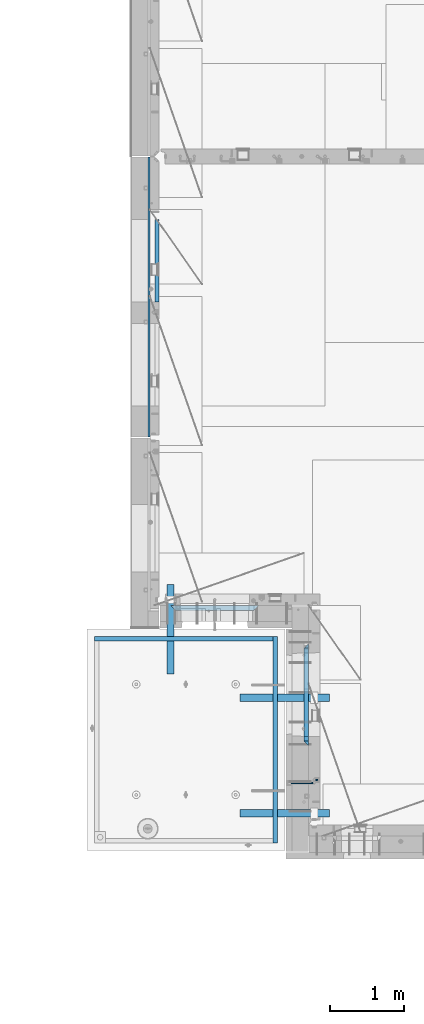
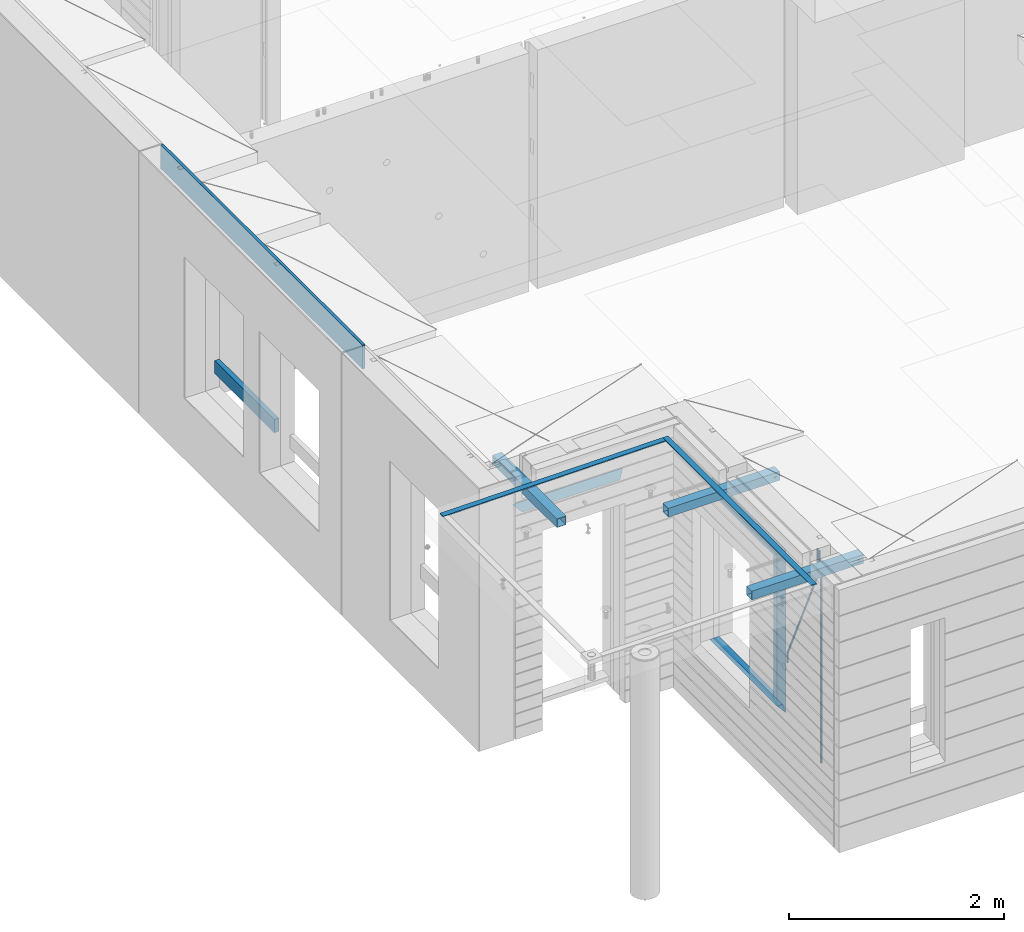
# One storey, part 88 of 341: 16 beams, 7 elements without a shape of their own.
"""IFC2X3 building model written with IfcOpenShell, lengths in millimetres."""

import ifcopenshell
import ifcopenshell.guid

model = None  # the IFC model being written
_history = None  # IfcOwnerHistory: only IFC2X3 demands one
_inside = {}  # id of a spatial element -> (the spatial element, [elements in it])
_under = {}  # id of a project, library or spatial element -> (it, [spatial elements below it])
_declared = {}  # id of a project -> (the project, [libraries it declares])
_typed = {}  # id of a type object -> (the type object, [elements of that type])
_made_of = {}  # id of a material, layer set ... -> (it, [elements and type objects made of it])


def new_model(schema):
    """Start an empty IFC model of exactly this schema.

    Asked for "IFC4X3", IfcOpenShell would pick the latest addendum, in which some entities
    have other attributes; the version numbers below select the first issue.
    IFC2X3 requires an IfcOwnerHistory on every rooted entity: one is made here for all.
    """
    global model, _history
    if schema == "IFC4X3":
        model = ifcopenshell.file(schema_version=(4, 3, 0, 0))
    else:
        model = ifcopenshell.file(schema=schema)
    _inside.clear()
    _under.clear()
    _declared.clear()
    _typed.clear()
    _made_of.clear()
    _history = None
    if model.schema == "IFC2X3":
        org = make("IfcOrganization", Name="unknown")
        user = make(
            "IfcPersonAndOrganization",
            ThePerson=make("IfcPerson", FamilyName="unknown"),
            TheOrganization=org,
        )
        app = make(
            "IfcApplication",
            ApplicationDeveloper=org,
            Version="unknown",
            ApplicationFullName="unknown",
            ApplicationIdentifier="unknown",
        )
        _history = make(
            "IfcOwnerHistory",
            OwningUser=user,
            OwningApplication=app,
            ChangeAction="ADDED",
            CreationDate=0,
        )
    return model


def make(cls, **values):
    """One entity of the class cls with the attributes given. An attribute that is None is left unset."""
    return model.create_entity(
        cls, **{name: value for name, value in values.items() if value is not None}
    )


def rooted(cls, **values):
    """An entity with a GlobalId (a new one), such as an element, a storey or a relation."""
    return make(cls, GlobalId=ifcopenshell.guid.new(), OwnerHistory=_history, **values)


def si_unit(unit_type, name, prefix=None):
    """IfcSIUnit, for example si_unit("LENGTHUNIT", "METRE", prefix="MILLI")."""
    return make("IfcSIUnit", UnitType=unit_type, Prefix=prefix, Name=name)


def assignment(units):
    """IfcUnitAssignment: the units of a project."""
    return None if units is None else make("IfcUnitAssignment", Units=units)


def point(xyz):
    """IfcCartesianPoint."""
    return None if xyz is None else make("IfcCartesianPoint", Coordinates=xyz)


def direction(xyz):
    """IfcDirection."""
    return None if xyz is None else make("IfcDirection", DirectionRatios=xyz)


def frame(location, z_axis=None, x_axis=None):
    """IfcAxis2Placement3D, a coordinate frame: its origin and axes. An axis left out is left unset."""
    return make(
        "IfcAxis2Placement3D",
        Location=point(location),
        Axis=direction(z_axis),
        RefDirection=direction(x_axis),
    )


def origin_with_axes():
    """The frame at (0, 0, 0) with the z axis (0, 0, 1) and the x axis (1, 0, 0) written out."""
    return frame((0.0, 0.0, 0.0), z_axis=(0.0, 0.0, 1.0), x_axis=(1.0, 0.0, 0.0))


def place(relative_to, where):
    """IfcLocalPlacement: puts the frame where relative to a parent placement (None: the world)."""
    return make(
        "IfcLocalPlacement", PlacementRelTo=relative_to, RelativePlacement=where
    )


def context(
    kind, dimensions, precision=None, world=None, true_north=None, identifier=None
):
    """IfcGeometricRepresentationContext, for example the 3D "Model" context."""
    return make(
        "IfcGeometricRepresentationContext",
        ContextIdentifier=identifier,
        ContextType=kind,
        CoordinateSpaceDimension=dimensions,
        Precision=precision,
        WorldCoordinateSystem=world,
        TrueNorth=true_north,
    )


def subcontext(parent, identifier, kind, view, scale=None):
    """IfcGeometricRepresentationSubContext, for example "Body" below "Model"."""
    return make(
        "IfcGeometricRepresentationSubContext",
        ContextIdentifier=identifier,
        ContextType=kind,
        ParentContext=parent,
        TargetScale=scale,
        TargetView=view,
    )


def project(units=None, contexts=None):
    """IfcProject with its units and contexts."""
    return rooted(
        "IfcProject",
        Name="project",
        RepresentationContexts=contexts,
        UnitsInContext=assignment(units),
    )


def spatial(cls, under=None, at=None, **own):
    """A site, building, storey or space (cls), placed at a placement, below another one or the project."""
    s = rooted(cls, ObjectPlacement=at, **own)
    if under is not None:
        _under.setdefault(under.id(), (under, []))[1].append(s)
    return s


def faces_of(points, faces, orient=None, outer=None):
    """IfcFace entities. A face is a list of loops; a loop is a list of indices into points, from 0.

    orient and outer hold one flag for each loop. By default every Orientation is true, the
    first loop of a face is its IfcFaceOuterBound and the others are IfcFaceBound.
    """
    made = []
    for i, loops in enumerate(faces):
        bounds = []
        for j, loop in enumerate(loops):
            is_outer = j == 0 if outer is None else outer[i][j]
            bounds.append(
                make(
                    "IfcFaceOuterBound" if is_outer else "IfcFaceBound",
                    Bound=make("IfcPolyLoop", Polygon=[points[k] for k in loop]),
                    Orientation=True if orient is None else orient[i][j],
                )
            )
        made.append(make("IfcFace", Bounds=bounds))
    return made


def faceted_brep(points, faces, orient=None, outer=None, voids=None):
    """IfcFacetedBrep: a solid bounded by flat faces; with voids (closed shells), ...WithVoids."""
    shared = [point(p) for p in points]
    hull = make("IfcClosedShell", CfsFaces=faces_of(shared, faces, orient, outer))
    if voids is None:
        return make("IfcFacetedBrep", Outer=hull)
    return make(
        "IfcFacetedBrepWithVoids",
        Outer=hull,
        Voids=[
            make(cls, CfsFaces=faces_of(shared, fs, o, b)) for cls, fs, o, b in voids
        ],
    )


def shape(context_of_items, identifier, shape_type, items):
    """IfcShapeRepresentation: the items that make up one representation, for example the "Body"."""
    return make(
        "IfcShapeRepresentation",
        ContextOfItems=context_of_items,
        RepresentationIdentifier=identifier,
        RepresentationType=shape_type,
        Items=items,
    )


def material(Name=None, Category=None):
    """IfcMaterial."""
    return make("IfcMaterial", Name=Name, Category=Category)


def made_of(thing, what):
    """Note that an element or type object is made of a material, layer set ...; save() writes the relation."""
    if what is not None:
        _made_of.setdefault(what.id(), (what, []))[1].append(thing)
    return thing


def type_object(cls, material=None, **own):
    """A type object (cls), such as IfcWallType, which elements share."""
    return made_of(rooted(cls, **own), material)


def element(
    cls,
    number,
    at=None,
    inside=None,
    cuts=None,
    type_object=None,
    material=None,
    context=None,
    identifier="Body",
    shape_type=None,
    held_by="IfcProductDefinitionShape",
    body=None,
    shapes=None,
    **own,
):
    """One element of the class cls, such as IfcWall. Its Tag is "e" and its number.

    at: its placement. inside: the storey or other place that contains it. cuts: it is an
    opening in that element (IfcRelVoidsElement). A single representation is given by context,
    identifier, shape_type and body (its items); several are given by shapes. held_by: the class
    of the entity that holds the representations. save() writes the other relations.
    """
    e = rooted(cls, Tag="e%d" % number, ObjectPlacement=at, **own)
    if body is not None:
        shapes = [shape(context, identifier, shape_type, body)]
    if shapes is not None:
        e.Representation = make(held_by, Representations=shapes)
    if inside is not None:
        _inside.setdefault(inside.id(), (inside, []))[1].append(e)
    if cuts is not None:
        rooted(
            "IfcRelVoidsElement", RelatingBuildingElement=cuts, RelatedOpeningElement=e
        )
    if type_object is not None:
        _typed.setdefault(type_object.id(), (type_object, []))[1].append(e)
    return made_of(e, material)


def aggregate(whole, parts):
    """IfcRelAggregates: a whole, such as a stair, and the parts it consists of."""
    return rooted("IfcRelAggregates", RelatingObject=whole, RelatedObjects=parts)


def save(model, path):
    """Write the relations noted so far, then the file.

    IfcRelAggregates (storeys below a building ...), IfcRelContainedInSpatialStructure (elements
    in a storey), IfcRelDefinesByType, IfcRelAssociatesMaterial and IfcRelDeclares: one each for
    every whole, place, type object, material and project.
    """
    for whole, parts in _under.values():
        aggregate(whole, parts)
    for where, things in _inside.values():
        rooted(
            "IfcRelContainedInSpatialStructure",
            RelatedElements=things,
            RelatingStructure=where,
        )
    for kind, things in _typed.values():
        rooted("IfcRelDefinesByType", RelatedObjects=things, RelatingType=kind)
    for what, things in _made_of.values():
        rooted("IfcRelAssociatesMaterial", RelatedObjects=things, RelatingMaterial=what)
    for by, libraries in _declared.values():
        rooted("IfcRelDeclares", RelatingContext=by, RelatedDefinitions=libraries)
    model.write(path)


model = new_model("IFC2X3")

# Units and contexts
model_context = context("Model", 3, precision=1e-05, world=origin_with_axes())
body_context = subcontext(model_context, "Body", "Model", "MODEL_VIEW")
ifc_project = project(units=[si_unit("LENGTHUNIT", "METRE", prefix="MILLI"), si_unit("AREAUNIT", "SQUARE_METRE"), si_unit("VOLUMEUNIT", "CUBIC_METRE"), si_unit("MASSUNIT", "GRAM", prefix="KILO"), si_unit("TIMEUNIT", "SECOND"), si_unit("PLANEANGLEUNIT", "RADIAN"), si_unit("SOLIDANGLEUNIT", "STERADIAN"), si_unit("THERMODYNAMICTEMPERATUREUNIT", "DEGREE_CELSIUS"), si_unit("LUMINOUSINTENSITYUNIT", "LUMEN")], contexts=[model_context])

# Site, building, storey
site_placement = place(None, origin_with_axes())
site = spatial("IfcSite", under=ifc_project, at=site_placement, CompositionType="ELEMENT")
building_placement = place(site_placement, origin_with_axes())
building = spatial("IfcBuilding", under=site, at=building_placement, CompositionType="ELEMENT")
storey_placement = place(building_placement, origin_with_axes())
storey = spatial("IfcBuildingStorey", under=building, at=storey_placement, Name="5", CompositionType="ELEMENT", Elevation=0.0)

# Assembly, beam
assembly_1_placement = place(storey_placement, origin_with_axes())
assembly_1 = element("IfcElementAssembly", 1, at=assembly_1_placement, inside=storey, AssemblyPlace="NOTDEFINED", PredefinedType="REINFORCEMENT_UNIT")
ifc_material_1 = material(Name="CONCRETE/C25/30")
beam_type_1 = type_object("IfcBeamType", PredefinedType="NOTDEFINED")
beam_1_placement = place(assembly_1_placement, frame((8155.00084638596, 10914.9999977209, 96160.0), z_axis=(0.0, 0.0, -1.0), x_axis=(1.0, 0.0, 0.0)))
beam_1 = element("IfcBeam", 2, at=beam_1_placement, type_object=beam_type_1, material=ifc_material_1, Name="SK", context=body_context, shape_type="Brep", body=[
    faceted_brep([(70.0000000000164, -35.0, 35.0), (70.0000000000164, 35.0, 35.0), (0.0, -35.0, -35.0), (1189.99771118164, -35.0, -35.0), (1119.99771118163, -35.0, 35.0), (1119.99771118163, 35.0, 35.0)], [[[0, 1, 2]], [[0, 2, 3, 4]], [[1, 0, 4, 5]], [[2, 1, 5, 3]], [[4, 3, 5]]]),
])
aggregate(assembly_1, [beam_1])

# Assembly, beams
assembly_2_placement = place(storey_placement, origin_with_axes())
assembly_2 = element("IfcElementAssembly", 3, at=assembly_2_placement, inside=storey, AssemblyPlace="NOTDEFINED", PredefinedType="REINFORCEMENT_UNIT")
ifc_material_2 = material()
beam_type_2 = type_object("IfcBeamType", Name="D20", PredefinedType="NOTDEFINED")
beam_2_placement = place(assembly_2_placement, frame((10084.9999999929, 8565.00000010149, 96442.5), z_axis=(-0.999999913638316, 0.000415599999849952, 0.0), x_axis=(0.0, 0.0, -1.0)))
beam_2 = element("IfcBeam", 4, at=beam_2_placement, type_object=beam_type_2, material=ifc_material_2, Name="JM20", ObjectType="D20", context=body_context, shape_type="Brep", body=[
    faceted_brep([(-0.00060564729210455, -9.99999998165731, 0.0), (-0.000428079845733009, -7.07106779890455, -7.07106781186667), (119.575515501536, -7.07830994756296, -7.07106481604933), (119.575337932896, -10.0072421307195, -3.43332612828817e-06), (0.0, 0.0, -10.0), (119.575943836026, -0.00724214867295814, -9.99999700418266), (0.00042843479604926, 7.07106779888636, -7.07106781186303), (119.57637202373, 7.06382565022977, -7.07106481604933), (0.00060564729210455, 9.99999998166459, 3.63797880709171e-12), (119.576549238118, 9.99275783300072, 2.99581552098971e-06), (0.000428079845733009, 7.07106779890819, 7.07106781186667), (119.576371669405, 7.06382565024978, 7.07107080768037), (0.0, 0.0, 10.0), (119.57594333493, -0.00724214864203532, 10.0000029958155), (-0.000428434810601175, -7.07106779888272, 7.07106781186667), (119.575515147211, -7.07830994754295, 7.07107080768037), (123.00654325854, -7.07836650239551, -6.96786008391246), (122.581588830741, -10.007295666459, 0.0904344953341933), (123.182419066041, -0.00729994480025198, -9.89151006310021), (123.006190977103, 7.06376911688858, -6.96788735351402), (122.581091016109, 9.99270432680532, 0.0903895128230943), (122.156136974867, 7.06377516229986, 7.14867767459873), (121.980261167351, -0.00729139528993983, 10.0723276537792), (122.156489256289, -7.07836045697513, 7.14870494419847), (237.49709662699, -7.07550578868904, -0.0736037829628913), (237.07214247236, -10.0044304077619, 6.98468625881105), (237.672972707907, -0.00444111421893467, -2.99725830022726), (237.496744892196, 7.06662983061869, -0.0736401287304034), (237.071645044241, 9.99556958684298, 6.98463485786669), (236.646690889625, 7.0666449686305, 14.0429248993696), (236.470814808708, -0.00441970584142837, 16.9665794166303), (236.64704262442, -7.07549065068088, 14.0429612451335), (256.280886861176, -7.07367819124556, 4.32379964430402), (253.529151791881, -10.0028291966883, 10.837375639805), (257.419749409892, -0.00251982142071938, 1.62558631567845), (256.278609203146, 7.06845724067534, 4.32331242818509), (253.525930697433, 9.99717053130007, 10.8366866126889), (250.774195628532, 7.06801952510796, 17.3502626086993), (249.635333079787, -0.00313884471142956, 20.0484759373085), (250.776473286547, -7.07411590680931, 17.3507498247964), (1044.79654444559, -6.93520549297136, 337.503576172079), (1042.04480937668, -9.86435649893974, 344.01715216822), (1045.93540699437, 0.135952876758893, 334.80536284325), (1044.79426678762, 7.20692993895318, 337.503088955587), (1042.04158828189, 10.1356432298053, 344.016463140051), (1039.28985321299, 7.20649222383872, 350.530039136193), (1038.1509906642, 0.135333854106648, 353.228252465022), (1039.29213087095, -6.93564320808582, 350.530526352686), (1045.80317501782, -6.93502871670898, 337.928918327147), (1044.37083345932, -9.86394802153518, 344.999991477245), (1046.39597922812, 0.136033758702979, 334.999973251357), (1045.80198942369, 7.20710690699525, 337.928892551829), (1044.36915677605, 10.1360519784266, 344.99995502544), (1042.93681521756, 7.20713267360225, 352.07102817554), (1042.34401100726, 0.136070198190282, 354.999973251332), (1042.93800081169, -6.93500295010017, 352.07105395086), (1046.89597924963, -6.93502871338751, 337.928918327145), (1046.89597925854, -9.86394801385723, 344.99999147724), (1046.89597922812, 0.136033760223654, 334.999973251355), (1046.89597920663, 7.20710691032036, 337.928892551825), (1046.89597919773, 10.1360519861082, 344.999955025434), (1046.89597920665, 7.20713268564032, 352.071028175533), (1046.89597922814, 0.136070212029153, 354.999973251321), (1046.89597924965, -6.93500293806574, 352.071053950853), (1152.50000002155, -6.93502839232315, 337.928918326952), (1152.50000003046, -9.86394769279468, 344.999991477047), (1152.50000000004, 0.136034081286198, 334.999973251162), (1152.49999997855, 7.20710723138291, 337.928892551632), (1152.49999996964, 10.1360523071726, 344.999955025241), (1152.49999997855, 7.20713300670286, 352.07102817534), (1152.50000000006, 0.136070533091697, 354.999973251128), (1152.50000002155, -6.93500261700319, 352.07105395066)], [[[0, 1, 2, 3]], [[1, 4, 5, 2]], [[4, 6, 7, 5]], [[6, 8, 9, 7]], [[8, 10, 11, 9]], [[10, 12, 13, 11]], [[12, 14, 15, 13]], [[14, 0, 3, 15]], [[14, 12, 10, 8, 6, 4, 1, 0]], [[3, 2, 16, 17]], [[2, 5, 18, 16]], [[5, 7, 19, 18]], [[7, 9, 20, 19]], [[9, 11, 21, 20]], [[11, 13, 22, 21]], [[13, 15, 23, 22]], [[15, 3, 17, 23]], [[17, 16, 24, 25]], [[16, 18, 26, 24]], [[18, 19, 27, 26]], [[19, 20, 28, 27]], [[20, 21, 29, 28]], [[21, 22, 30, 29]], [[22, 23, 31, 30]], [[23, 17, 25, 31]], [[25, 24, 32, 33]], [[24, 26, 34, 32]], [[26, 27, 35, 34]], [[27, 28, 36, 35]], [[28, 29, 37, 36]], [[29, 30, 38, 37]], [[30, 31, 39, 38]], [[31, 25, 33, 39]], [[33, 32, 40, 41]], [[32, 34, 42, 40]], [[34, 35, 43, 42]], [[35, 36, 44, 43]], [[36, 37, 45, 44]], [[37, 38, 46, 45]], [[38, 39, 47, 46]], [[39, 33, 41, 47]], [[41, 40, 48, 49]], [[40, 42, 50, 48]], [[42, 43, 51, 50]], [[43, 44, 52, 51]], [[44, 45, 53, 52]], [[45, 46, 54, 53]], [[46, 47, 55, 54]], [[47, 41, 49, 55]], [[49, 48, 56, 57]], [[48, 50, 58, 56]], [[50, 51, 59, 58]], [[51, 52, 60, 59]], [[52, 53, 61, 60]], [[53, 54, 62, 61]], [[54, 55, 63, 62]], [[55, 49, 57, 63]], [[57, 56, 64, 65]], [[56, 58, 66, 64]], [[58, 59, 67, 66]], [[59, 60, 68, 67]], [[60, 61, 69, 68]], [[61, 62, 70, 69]], [[62, 63, 71, 70]], [[63, 57, 65, 71]], [[66, 67, 68, 69, 70, 71, 65, 64]]]),
])
beam_3_placement = place(assembly_2_placement, frame((10085.0, 8604.99999989851, 96442.5), z_axis=(0.999999913638316, -0.000415599999849952, 0.0), x_axis=(0.0, -4.69819999911136e-05, -0.999999998896346)))
beam_3 = element("IfcBeam", 5, at=beam_3_placement, type_object=beam_type_2, material=ifc_material_2, Name="JM20", ObjectType="D20", context=body_context, shape_type="Brep", body=[
    faceted_brep([(0.0, -10.0, 0.0), (-4.19531716033816e-08, -7.07106781186667, -7.07106781187031), (148.248091248824, -7.07106843456495, -7.07106781132279), (148.248091238493, -10.0000006235969, -4.32919478043914e-10), (0.0, 0.0, -10.0), (148.248091277143, -6.2269828049466e-07, -9.99999999945976), (4.196772351861e-08, 7.07106781186303, -7.07106781186667), (148.24809130824, 7.07106718916839, -7.07106781132097), (0.0, 10.0, 0.0), (148.248091323869, 9.9999993772999, 5.42058842256665e-10), (4.196772351861e-08, 7.07106781185939, 7.07106781185939), (148.248091314905, 7.07106718916657, 7.07106781241055), (0.0, 0.0, 10.0), (148.248091286572, -6.2269828049466e-07, 10.0000000005421), (-4.19531716033816e-08, -7.07106781187031, 7.07106781185939), (148.248091255489, -7.07106843456495, 7.07106781240873), (165.700159784406, -7.06953248082573, -4.33740745191608), (163.538514001601, -9.99865491429591, 2.3950640878993), (166.594536354663, 0.00161404504797247, -7.12624612062973), (165.697730045635, 7.07260292898718, -4.33778805080874), (163.535077830456, 10.0013447821748, 2.39452583837374), (161.373432045977, 7.07222234770961, 9.1269973767794), (160.479055475793, 0.00107582183773047, 11.9158360455003), (161.375861784734, -7.06991306209602, 9.12737797566297), (275.336574769928, -7.04974841841067, 30.8729968105745), (273.174928982757, -9.97887085451111, 37.6054683469883), (276.230951340302, 0.0213981074375624, 28.0841581417499), (275.33414503136, 7.09238699147681, 30.8726162114253), (273.171492816051, 10.0211288448281, 37.604930100495), (271.009847031426, 7.09200641048847, 44.3374016388952), (270.115470461067, 0.020859884645688, 47.1262403077217), (271.012276770023, -7.05012899939356, 44.3377822380444), (288.462247429605, -7.04827729996032, 32.928978237067), (288.462385179082, -9.97715744086236, 40.000067606923), (288.461915156615, 0.0227689473176724, 29.9999940068319), (288.461582998585, 7.09385830774227, 32.9288741527089), (288.461445529087, 10.0228425347159, 39.9999204078104), (288.461583275901, 7.09396239205853, 47.071009776073), (288.461915548847, 0.0229161447769002, 49.9999940063062), (288.462247706979, -7.0481732156386, 47.0711138604311), (2452.50033006088, -6.94660565975028, 32.9289359853719), (2452.50046780803, -9.87548580226576, 40.0000253536709), (2452.49999778777, 0.124440587491335, 29.9999517550186), (2452.49966562983, 7.19552994798869, 32.9288319007737), (2452.49952816062, 10.1245141751169, 39.9998781558224), (2452.49966590777, 7.19563403259781, 47.0709675241233), (2452.49999818087, 0.124587785358017, 49.9999517544766), (2452.50033033882, -6.94650157513934, 47.0710716087196)], [[[0, 1, 2, 3]], [[1, 4, 5, 2]], [[4, 6, 7, 5]], [[6, 8, 9, 7]], [[8, 10, 11, 9]], [[10, 12, 13, 11]], [[12, 14, 15, 13]], [[14, 0, 3, 15]], [[14, 12, 10, 8, 6, 4, 1, 0]], [[3, 2, 16, 17]], [[2, 5, 18, 16]], [[5, 7, 19, 18]], [[7, 9, 20, 19]], [[9, 11, 21, 20]], [[11, 13, 22, 21]], [[13, 15, 23, 22]], [[15, 3, 17, 23]], [[17, 16, 24, 25]], [[16, 18, 26, 24]], [[18, 19, 27, 26]], [[19, 20, 28, 27]], [[20, 21, 29, 28]], [[21, 22, 30, 29]], [[22, 23, 31, 30]], [[23, 17, 25, 31]], [[25, 24, 32, 33]], [[24, 26, 34, 32]], [[26, 27, 35, 34]], [[27, 28, 36, 35]], [[28, 29, 37, 36]], [[29, 30, 38, 37]], [[30, 31, 39, 38]], [[31, 25, 33, 39]], [[33, 32, 40, 41]], [[32, 34, 42, 40]], [[34, 35, 43, 42]], [[35, 36, 44, 43]], [[36, 37, 45, 44]], [[37, 38, 46, 45]], [[38, 39, 47, 46]], [[39, 33, 41, 47]], [[42, 43, 44, 45, 46, 47, 41, 40]]]),
])

# Assembly, beam
assembly_3_placement = place(storey_placement, origin_with_axes())
assembly_3 = element("IfcElementAssembly", 6, at=assembly_3_placement, inside=storey, AssemblyPlace="NOTDEFINED", PredefinedType="REINFORCEMENT_UNIT")
ifc_material_3 = material(Name="TIMBER/T24")
beam_type_3 = type_object("IfcBeamType", PredefinedType="NOTDEFINED")
beam_4_placement = place(assembly_3_placement, frame((7975.00000026382, 16134.5170325064, 94685.0), z_axis=(0.0, 0.0, 1.0), x_axis=(0.0, -1.0, 0.0)))
beam_4 = element("IfcBeam", 7, at=beam_4_placement, type_object=beam_type_3, material=ifc_material_3, context=body_context, shape_type="Brep", body=[
    faceted_brep([(-3.63797880709171e-12, 24.9999999999964, -75.0), (-3.63797880709171e-12, 24.9999999999964, 75.0), (1109.51662173163, 25.0, 75.0), (1109.51662173163, 25.0, -75.0), (0.0, -25.0000000000073, 75.0), (1109.51662173163, -25.0, 75.0), (0.0, -25.0000000000073, -75.0), (1109.51662173163, -25.0, -75.0)], [[[0, 1, 2, 3]], [[1, 4, 5, 2]], [[4, 6, 7, 5]], [[6, 0, 3, 7]], [[5, 7, 3, 2]], [[6, 4, 1, 0]]]),
])

# Assemblies, beams
assembly_4_placement = place(storey_placement, origin_with_axes())
assembly_4 = element("IfcElementAssembly", 8, at=assembly_4_placement, inside=storey, AssemblyPlace="NOTDEFINED", PredefinedType="REINFORCEMENT_UNIT")
assembly_5_placement = place(assembly_4_placement, origin_with_axes())
assembly_5 = element("IfcElementAssembly", 9, at=assembly_5_placement, AssemblyPlace="NOTDEFINED", PredefinedType="NOTDEFINED")
ifc_material_4 = material(Name="Undefined/350")
beam_type_4 = type_object("IfcBeamType", Name="100X100X5", PredefinedType="NOTDEFINED")
beam_5_placement = place(assembly_5_placement, frame((8154.95985679893, 10029.9865573969, 96555.0), z_axis=(0.0, 0.0, 1.0), x_axis=(2.22429999942101e-05, 0.999999999752625, 0.0)))
beam_5 = element("IfcBeam", 10, at=beam_5_placement, type_object=beam_type_4, material=ifc_material_4, ObjectType="100X100X5", context=body_context, shape_type="Brep", body=[
    faceted_brep([(1160.82642950046, -49.9743978761207, -6.25), (1160.82642783901, -44.9999999999991, -6.25), (1156.25111029171, -44.9999999999991, -10.8253175473074), (1156.25111195316, -49.9743994042774, -10.8253175473074), (1150.00111029171, -44.9999999999991, -12.5), (1150.00111195316, -49.9744014917787, -12.5), (1143.75111029171, -44.9999999999991, -10.8253175473074), (1143.75111195316, -49.9744035792783, -10.8253175473074), (1139.1757927444, -44.9999999999991, -6.25), (1139.17579440585, -49.9744051074349, -6.25), (1137.50111029171, -44.9999999999991, 0.0), (1137.50111195316, -49.9744056667778, 0.0), (1139.1757927444, -44.9999999999991, 6.25), (1139.17579440585, -49.9744051074349, 6.25), (1143.75111029171, -44.9999999999991, 10.8253175473074), (1143.75111195316, -49.9744035792783, 10.8253175473074), (1150.00111029171, -44.9999999999991, 12.5), (1150.00111195316, -49.9744014917787, 12.5), (1156.25111029171, -44.9999999999991, 10.8253175473074), (1156.25111195316, -49.9743994042774, 10.8253175473074), (1160.82642783901, -44.9999999999991, 6.25), (1160.82642950046, -49.9743978761207, 6.25), (1162.50111029171, -44.9999999999991, 0.0), (1162.50111195316, -49.9743973167779, 0.0), (1160.82639777901, 44.9999999999982, -6.25), (1160.82639610046, 50.0256021227788, -6.25), (1156.25107855315, 50.0256005946221, -10.8253175473074), (1156.2510802317, 44.9999999999982, -10.8253175473074), (1150.00107855316, 50.0255985071226, -12.5), (1150.00108023171, 44.9999999999982, -12.5), (1143.75107855316, 50.0255964196231, -10.8253175473074), (1143.75108023171, 44.9999999999982, -10.8253175473074), (1139.17576100585, 50.0255948914664, -6.25), (1139.1757626844, 44.9999999999982, -6.25), (1137.50107855316, 50.0255943321226, 0.0), (1137.5010802317, 44.9999999999982, 0.0), (1139.17576100585, 50.0255948914664, 6.25), (1139.1757626844, 44.9999999999982, 6.25), (1143.75107855316, 50.0255964196231, 10.8253175473074), (1143.75108023171, 44.9999999999982, 10.8253175473074), (1150.00107855316, 50.0255985071226, 12.5), (1150.00108023171, 44.9999999999982, 12.5), (1156.25107855315, 50.0256005946221, 10.8253175473074), (1156.2510802317, 44.9999999999982, 10.8253175473074), (1160.82639610046, 50.0256021227788, 6.25), (1160.82639777901, 44.9999999999982, 6.25), (1162.50107855316, 50.0256026821226, 0.0), (1162.50108023171, 44.9999999999982, 0.0), (1.81898940354586e-12, -50.0000000000009, -50.0), (1.81898940354586e-12, 49.9999999999991, -50.0), (1200.00449189278, 49.9999999999982, -50.0), (1200.00449189278, -50.0000000000009, -50.0), (1.81898940354586e-12, -50.0000000000009, 50.0), (1200.00449189278, -50.0000000000009, 50.0), (1.81898940354586e-12, 49.9999999999991, 50.0), (1200.00449189278, 49.9999999999982, 50.0), (0.0, 44.9999999999991, 45.0), (1.81898940354586e-12, -45.0000000000009, 45.0), (1.81898940354586e-12, -45.0000000000009, -45.0), (0.0, 44.9999999999991, -45.0), (1200.00449189278, 44.9999999999982, -45.0), (1200.00449189278, 44.9999999999982, 45.0), (1200.00449189278, -45.0000000000009, 45.0), (1200.00449189278, -45.0000000000009, -45.0)], [[[0, 1, 2, 3]], [[3, 2, 4, 5]], [[5, 4, 6, 7]], [[7, 6, 8, 9]], [[9, 8, 10, 11]], [[11, 10, 12, 13]], [[13, 12, 14, 15]], [[15, 14, 16, 17]], [[17, 16, 18, 19]], [[19, 18, 20, 21]], [[21, 20, 22, 23]], [[23, 22, 1, 0]], [[24, 25, 26, 27]], [[27, 26, 28, 29]], [[29, 28, 30, 31]], [[31, 30, 32, 33]], [[33, 32, 34, 35]], [[35, 34, 36, 37]], [[37, 36, 38, 39]], [[39, 38, 40, 41]], [[41, 40, 42, 43]], [[43, 42, 44, 45]], [[45, 44, 46, 47]], [[47, 46, 25, 24]], [[48, 49, 50, 51]], [[52, 48, 51, 53], [3, 5, 7, 9, 11, 13, 15, 17, 19, 21, 23, 0]], [[54, 52, 53, 55]], [[48, 52, 54, 49], [56, 57, 58, 59]], [[56, 59, 60, 61], [27, 29, 31, 33, 35, 37, 39, 41, 43, 45, 47, 24]], [[57, 56, 61, 62]], [[58, 57, 62, 63], [18, 16, 14, 12, 10, 8, 6, 4, 2, 1, 22, 20]], [[59, 58, 63, 60]], [[53, 51, 50, 55], [62, 61, 60, 63]], [[49, 54, 55, 50], [42, 40, 38, 36, 34, 32, 30, 28, 26, 25, 46, 44]]]),
])
aggregate(assembly_5, [beam_5])
assembly_6_placement = place(assembly_4_placement, origin_with_axes())
assembly_6 = element("IfcElementAssembly", 11, at=assembly_6_placement, AssemblyPlace="NOTDEFINED", PredefinedType="NOTDEFINED")
beam_6_placement = place(assembly_6_placement, frame((9089.99655739692, 9710.00014320107, 96555.0), z_axis=(0.0, 0.0, 1.0), x_axis=(0.999999999752625, -2.22429999942101e-05, 0.0)))
beam_6 = element("IfcBeam", 12, at=beam_6_placement, type_object=beam_type_4, material=ifc_material_4, ObjectType="100X100X5", context=body_context, shape_type="Brep", body=[
    faceted_brep([(1156.2510802317, 44.9999999999982, 10.8253175473074), (1156.25107855315, 50.0256005946221, 10.8253175473074), (1160.82639610046, 50.0256021227788, 6.25), (1160.82639777901, 44.9999999999982, 6.25), (1150.00108023171, 44.9999999999982, 12.5), (1150.00107855316, 50.0255985071226, 12.5), (1143.75108023171, 44.9999999999982, 10.8253175473074), (1143.75107855316, 50.0255964196231, 10.8253175473074), (1139.1757626844, 44.9999999999982, 6.25), (1139.17576100585, 50.0255948914664, 6.25), (1137.5010802317, 44.9999999999982, 0.0), (1137.50107855316, 50.0255943321226, 0.0), (1139.1757626844, 44.9999999999982, -6.25), (1139.17576100585, 50.0255948914664, -6.25), (1143.75108023171, 44.9999999999982, -10.8253175473074), (1143.75107855316, 50.0255964196231, -10.8253175473074), (1150.00108023171, 44.9999999999982, -12.5), (1150.00107855316, 50.0255985071226, -12.5), (1156.2510802317, 44.9999999999982, -10.8253175473074), (1156.25107855315, 50.0256005946221, -10.8253175473074), (1160.82639777901, 44.9999999999982, -6.25), (1160.82639610046, 50.0256021227788, -6.25), (1162.50108023171, 44.9999999999982, 0.0), (1162.50107855316, 50.0256026821226, 0.0), (1156.25111195316, -49.9743994042774, 10.8253175473074), (1156.25111029171, -44.9999999999991, 10.8253175473074), (1160.82642783901, -44.9999999999991, 6.25), (1160.82642950046, -49.9743978761207, 6.25), (1150.00111195316, -49.9744014917787, 12.5), (1150.00111029171, -44.9999999999991, 12.5), (1143.75111195316, -49.9744035792783, 10.8253175473074), (1143.75111029171, -44.9999999999991, 10.8253175473074), (1139.17579440585, -49.9744051074349, 6.25), (1139.1757927444, -44.9999999999991, 6.25), (1137.50111195316, -49.9744056667778, 0.0), (1137.50111029171, -44.9999999999991, 0.0), (1139.17579440585, -49.9744051074349, -6.25), (1139.1757927444, -44.9999999999991, -6.25), (1143.75111195316, -49.9744035792783, -10.8253175473074), (1143.75111029171, -44.9999999999991, -10.8253175473074), (1150.00111195316, -49.9744014917787, -12.5), (1150.00111029171, -44.9999999999991, -12.5), (1156.25111195316, -49.9743994042774, -10.8253175473074), (1156.25111029171, -44.9999999999991, -10.8253175473074), (1160.82642950046, -49.9743978761207, -6.25), (1160.82642783901, -44.9999999999991, -6.25), (1162.50111195316, -49.9743973167779, 0.0), (1162.50111029171, -44.9999999999991, 0.0), (1.81898940354586e-12, -50.0000000000009, -50.0), (1.81898940354586e-12, 49.9999999999991, -50.0), (1200.00449189278, 49.9999999999982, -50.0), (1200.00449189278, -50.0000000000009, -50.0), (1.81898940354586e-12, 49.9999999999991, 50.0), (1.81898940354586e-12, -50.0000000000009, 50.0), (1200.00449189278, -50.0000000000009, 50.0), (1200.00449189278, 49.9999999999982, 50.0), (0.0, 44.9999999999991, 45.0), (1.81898940354586e-12, -45.0000000000009, 45.0), (1.81898940354586e-12, -45.0000000000009, -45.0), (0.0, 44.9999999999991, -45.0), (1200.00449189278, 44.9999999999982, -45.0), (1200.00449189278, 44.9999999999982, 45.0), (1200.00449189278, -45.0000000000009, 45.0), (1200.00449189278, -45.0000000000009, -45.0)], [[[0, 1, 2, 3]], [[4, 5, 1, 0]], [[6, 7, 5, 4]], [[8, 9, 7, 6]], [[10, 11, 9, 8]], [[12, 13, 11, 10]], [[14, 15, 13, 12]], [[16, 17, 15, 14]], [[18, 19, 17, 16]], [[20, 21, 19, 18]], [[22, 23, 21, 20]], [[3, 2, 23, 22]], [[24, 25, 26, 27]], [[28, 29, 25, 24]], [[30, 31, 29, 28]], [[32, 33, 31, 30]], [[34, 35, 33, 32]], [[36, 37, 35, 34]], [[38, 39, 37, 36]], [[40, 41, 39, 38]], [[42, 43, 41, 40]], [[44, 45, 43, 42]], [[46, 47, 45, 44]], [[27, 26, 47, 46]], [[48, 49, 50, 51]], [[52, 53, 54, 55]], [[49, 52, 55, 50], [1, 5, 7, 9, 11, 13, 15, 17, 19, 21, 23, 2]], [[48, 53, 52, 49], [56, 57, 58, 59]], [[56, 59, 60, 61], [18, 16, 14, 12, 10, 8, 6, 4, 0, 3, 22, 20]], [[57, 56, 61, 62]], [[58, 57, 62, 63], [25, 29, 31, 33, 35, 37, 39, 41, 43, 45, 47, 26]], [[59, 58, 63, 60]], [[54, 51, 50, 55], [62, 61, 60, 63]], [[53, 48, 51, 54], [42, 40, 38, 36, 34, 32, 30, 28, 24, 27, 46, 44]]]),
])
aggregate(assembly_6, [beam_6])
assembly_7_placement = place(assembly_4_placement, origin_with_axes())
assembly_7 = element("IfcElementAssembly", 13, at=assembly_7_placement, AssemblyPlace="NOTDEFINED", PredefinedType="NOTDEFINED")
beam_7_placement = place(assembly_7_placement, frame((9089.99655739692, 8155.00014320107, 96555.0), z_axis=(0.0, 0.0, 1.0), x_axis=(0.999999999752625, -2.22429999942101e-05, 0.0)))
beam_7 = element("IfcBeam", 14, at=beam_7_placement, type_object=beam_type_4, material=ifc_material_4, ObjectType="100X100X5", context=body_context, shape_type="Brep", body=[
    faceted_brep([(1156.2510802317, 44.9999999999982, 10.8253175473074), (1156.25107855315, 50.0256005946221, 10.8253175473074), (1160.82639610046, 50.0256021227788, 6.25), (1160.82639777901, 44.9999999999982, 6.25), (1150.00108023171, 44.9999999999982, 12.5), (1150.00107855316, 50.0255985071226, 12.5), (1143.75108023171, 44.9999999999982, 10.8253175473074), (1143.75107855316, 50.0255964196231, 10.8253175473074), (1139.1757626844, 44.9999999999982, 6.25), (1139.17576100585, 50.0255948914664, 6.25), (1137.5010802317, 44.9999999999982, 0.0), (1137.50107855316, 50.0255943321226, 0.0), (1139.1757626844, 44.9999999999982, -6.25), (1139.17576100585, 50.0255948914664, -6.25), (1143.75108023171, 44.9999999999982, -10.8253175473074), (1143.75107855316, 50.0255964196231, -10.8253175473074), (1150.00108023171, 44.9999999999982, -12.5), (1150.00107855316, 50.0255985071226, -12.5), (1156.2510802317, 44.9999999999982, -10.8253175473074), (1156.25107855315, 50.0256005946221, -10.8253175473074), (1160.82639777901, 44.9999999999982, -6.25), (1160.82639610046, 50.0256021227788, -6.25), (1162.50108023171, 44.9999999999982, 0.0), (1162.50107855316, 50.0256026821226, 0.0), (1156.25111195316, -49.9743994042774, 10.8253175473074), (1156.25111029171, -44.9999999999991, 10.8253175473074), (1160.82642783901, -44.9999999999991, 6.25), (1160.82642950046, -49.9743978761207, 6.25), (1150.00111195316, -49.9744014917787, 12.5), (1150.00111029171, -44.9999999999991, 12.5), (1143.75111195316, -49.9744035792783, 10.8253175473074), (1143.75111029171, -44.9999999999991, 10.8253175473074), (1139.17579440585, -49.9744051074349, 6.25), (1139.1757927444, -44.9999999999991, 6.25), (1137.50111195316, -49.9744056667778, 0.0), (1137.50111029171, -44.9999999999991, 0.0), (1139.17579440585, -49.9744051074349, -6.25), (1139.1757927444, -44.9999999999991, -6.25), (1143.75111195316, -49.9744035792783, -10.8253175473074), (1143.75111029171, -44.9999999999991, -10.8253175473074), (1150.00111195316, -49.9744014917787, -12.5), (1150.00111029171, -44.9999999999991, -12.5), (1156.25111195316, -49.9743994042774, -10.8253175473074), (1156.25111029171, -44.9999999999991, -10.8253175473074), (1160.82642950046, -49.9743978761207, -6.25), (1160.82642783901, -44.9999999999991, -6.25), (1162.50111195316, -49.9743973167779, 0.0), (1162.50111029171, -44.9999999999991, 0.0), (1.81898940354586e-12, -50.0000000000009, -50.0), (1.81898940354586e-12, 49.9999999999991, -50.0), (1200.00449189278, 49.9999999999982, -50.0), (1200.00449189278, -50.0000000000009, -50.0), (1.81898940354586e-12, 49.9999999999991, 50.0), (1.81898940354586e-12, -50.0000000000009, 50.0), (1200.00449189278, -50.0000000000009, 50.0), (1200.00449189278, 49.9999999999982, 50.0), (0.0, 44.9999999999991, 45.0), (1.81898940354586e-12, -45.0000000000009, 45.0), (1.81898940354586e-12, -45.0000000000009, -45.0), (0.0, 44.9999999999991, -45.0), (1200.00449189278, 44.9999999999982, -45.0), (1200.00449189278, 44.9999999999982, 45.0), (1200.00449189278, -45.0000000000009, 45.0), (1200.00449189278, -45.0000000000009, -45.0)], [[[0, 1, 2, 3]], [[4, 5, 1, 0]], [[6, 7, 5, 4]], [[8, 9, 7, 6]], [[10, 11, 9, 8]], [[12, 13, 11, 10]], [[14, 15, 13, 12]], [[16, 17, 15, 14]], [[18, 19, 17, 16]], [[20, 21, 19, 18]], [[22, 23, 21, 20]], [[3, 2, 23, 22]], [[24, 25, 26, 27]], [[28, 29, 25, 24]], [[30, 31, 29, 28]], [[32, 33, 31, 30]], [[34, 35, 33, 32]], [[36, 37, 35, 34]], [[38, 39, 37, 36]], [[40, 41, 39, 38]], [[42, 43, 41, 40]], [[44, 45, 43, 42]], [[46, 47, 45, 44]], [[27, 26, 47, 46]], [[48, 49, 50, 51]], [[52, 53, 54, 55]], [[49, 52, 55, 50], [1, 5, 7, 9, 11, 13, 15, 17, 19, 21, 23, 2]], [[48, 53, 52, 49], [56, 57, 58, 59]], [[56, 59, 60, 61], [18, 16, 14, 12, 10, 8, 6, 4, 0, 3, 22, 20]], [[57, 56, 61, 62]], [[58, 57, 62, 63], [25, 29, 31, 33, 35, 37, 39, 41, 43, 45, 47, 26]], [[59, 58, 63, 60]], [[54, 51, 50, 55], [62, 61, 60, 63]], [[53, 48, 51, 54], [42, 40, 38, 36, 34, 32, 30, 28, 24, 27, 46, 44]]]),
])
aggregate(assembly_7, [beam_7])
ifc_material_5 = material(Name="CONCRETE/Concrete_Undefined")
beam_type_5 = type_object("IfcBeamType", PredefinedType="NOTDEFINED")
beam_8_placement = place(assembly_4_placement, frame((9529.73225763201, 10500.0586098955, 96724.6636624749), z_axis=(-0.00918619300035676, -2.22000000585005e-07, 0.99995780603889), x_axis=(-0.999957805748064, -2.41189999941813e-05, -0.00918619299768504)))
beam_8 = element("IfcBeam", 15, at=beam_8_placement, type_object=beam_type_5, material=ifc_material_5, context=body_context, shape_type="Brep", body=[
    faceted_brep([(2.5465851649642e-11, 29.9999999999982, -4.99999999998545), (-2.91038304567337e-11, 29.9999999999982, 5.0), (2394.89682739776, 29.9999999999964, 5.0), (2394.89682739781, 30.0, -4.99999999998545), (-2.5465851649642e-11, -30.0000000000018, 5.0), (2394.89682739776, -30.0000000000036, 5.0), (2.72848410531878e-11, -30.0000000000018, -4.99999999998545), (2394.89682739781, -30.0, -4.99999999998545)], [[[0, 1, 2, 3]], [[1, 4, 5, 2]], [[4, 6, 7, 5]], [[6, 0, 3, 7]], [[5, 7, 3, 2]], [[6, 4, 1, 0]]]),
])
beam_9_placement = place(assembly_4_placement, frame((9559.6242765169, 7760.00786459139, 96724.2917943147), z_axis=(-2.9999991954625e-09, -0.000129499999950134, 0.999999991614875), x_axis=(2.43220000075427e-05, 0.999999991319095, 0.000129500000041638)))
beam_9 = element("IfcBeam", 16, at=beam_9_placement, type_object=beam_type_5, material=ifc_material_5, context=body_context, shape_type="Brep", body=[
    faceted_brep([(2.5465851649642e-11, 29.9999999999982, -4.99999999998545), (-2.91038304567337e-11, 29.9999999999982, 5.0), (2770.00002322912, 29.9999999999982, 5.00000000001455), (2770.00002322912, 29.9999999999982, -4.9999999999709), (-2.5465851649642e-11, -30.0000000000018, 5.0), (2770.00002322912, -30.0000000000018, 5.0), (2.72848410531878e-11, -30.0000000000018, -4.99999999998545), (2770.00002322912, -30.0000000000018, -4.99999999998545)], [[[0, 1, 2, 3]], [[1, 4, 5, 2]], [[4, 6, 7, 5]], [[6, 0, 3, 7]], [[5, 7, 3, 2]], [[6, 4, 1, 0]]]),
])
aggregate(assembly_4, [beam_8, assembly_5, assembly_6, assembly_7, beam_9])

# Beam
beam_type_6 = type_object("IfcBeamType", PredefinedType="NOTDEFINED")
beam_10_placement = place(assembly_2_placement, frame((9980.0, 10435.001591409, 96145.0), z_axis=(0.0, 0.0, -1.0), x_axis=(0.0, -1.0, 0.0)))
beam_10 = element("IfcBeam", 17, at=beam_10_placement, type_object=beam_type_6, material=ifc_material_1, Name="SK", context=body_context, shape_type="Brep", body=[
    faceted_brep([(60.0000000000073, 30.0, 30.0), (0.0, -30.0, -30.0), (60.0000000000073, -30.0, 30.0), (1309.99847412109, -30.0, 30.0), (1309.99847412109, 30.0, 30.0), (1369.99847412109, -30.0, -30.0)], [[[0, 1, 2]], [[0, 2, 3, 4]], [[1, 0, 4, 5]], [[2, 1, 5, 3]], [[4, 3, 5]]]),
])

beam_11_placement = place(assembly_2_placement, frame((9980.00000000155, 10375.001591409, 96085.0), z_axis=(0.0, 0.0, -1.0), x_axis=(0.0, -1.0, 0.0)))
beam_11 = element("IfcBeam", 18, at=beam_11_placement, type_object=beam_type_6, material=ifc_material_1, Name="SK", context=body_context, shape_type="Brep", body=[
    faceted_brep([(65.6741497967687, 29.999999998452, 26.2921283848846), (0.0, 30.0, -30.0), (0.0, -30.0, -30.0), (64.0525281752307, -29.999999998452, 24.9021669953072), (64.0525281752307, -29.999999998452, 24.0540540541406), (65.6741497967687, 29.999999998452, 25.6756756756804), (1185.94442006696, -29.999999998452, 24.0540540541406), (1184.32279844542, 29.999999998452, 25.6756756756804), (1185.94442006696, -29.999999998452, 24.9034748915001), (1184.32279844542, 29.999999998452, 26.2934362810629), (1249.99847412109, 29.999999998452, -30.0), (1249.99847412109, -29.999999998452, -30.0)], [[[0, 1, 2, 3]], [[4, 5, 0, 3]], [[6, 7, 5, 4]], [[7, 6, 8, 9]], [[1, 0, 5, 7, 9, 10]], [[2, 1, 10, 11]], [[6, 4, 3, 2, 11, 8]], [[10, 9, 8, 11]]]),
])

beam_12_placement = place(assembly_2_placement, frame((9980.0, 9095.00311728789, 96175.0), z_axis=(0.0, 1.0, 0.0), x_axis=(0.0, 0.0, -1.0)))
beam_12 = element("IfcBeam", 19, at=beam_12_placement, type_object=beam_type_6, material=ifc_material_1, Name="SK", context=body_context, shape_type="Brep", body=[
    faceted_brep([(60.0000000000073, 30.0, 30.0), (0.0, -30.0, -30.0), (60.0000000000073, -30.0, 30.0), (1795.00000000001, -30.0, 30.0), (1795.00000000001, 30.0, 30.0), (1855.0, -30.0, -30.0)], [[[0, 1, 2]], [[3, 4, 0, 2]], [[4, 5, 1, 0]], [[5, 3, 2, 1]], [[3, 5, 4]]]),
])

beam_13_placement = place(assembly_2_placement, frame((9980.0, 9065.00311728789, 94350.0), z_axis=(0.0, 0.0, 1.0), x_axis=(0.0, 1.0, 0.0)))
beam_13 = element("IfcBeam", 20, at=beam_13_placement, type_object=beam_type_6, material=ifc_material_1, Name="SK", context=body_context, shape_type="Brep", body=[
    faceted_brep([(1309.99847412109, 30.0, 30.0), (1309.99847412109, -30.0, 30.0), (1369.99847412109, -30.0, -30.0), (60.0000000000073, -30.0, 30.0), (0.0, -30.0, -30.0), (60.0000000000073, 30.0, 30.0)], [[[0, 1, 2]], [[3, 4, 2, 1]], [[4, 5, 0, 2]], [[5, 3, 1, 0]], [[5, 4, 3]]]),
])

beam_14_placement = place(assembly_2_placement, frame((9980.00000000155, 9125.00311728789, 94410.0), z_axis=(0.0, 0.0, 1.0), x_axis=(0.0, 1.0, 0.0)))
beam_14 = element("IfcBeam", 21, at=beam_14_placement, type_object=beam_type_6, material=ifc_material_1, Name="SK", context=body_context, shape_type="Brep", body=[
    faceted_brep([(1184.32432432433, 29.999999998452, 26.2921283848846), (1185.94594594586, -29.999999998452, 24.9021669952926), (1249.99847412109, -29.999999998452, -30.0), (1249.99847412109, 29.999999998452, -30.0), (1184.32432432432, 29.9999988381387, 25.6756756756804), (1185.94594588314, -29.9999988381387, 24.0540541168593), (65.6756756756768, 30.0, 25.6756756756804), (64.0540540540533, -30.0, 24.0540540540533), (64.0540540540533, -30.0, 24.9034748914419), (0.0, -30.0, -30.0), (0.0, 30.0, -30.0), (65.6756756756768, 30.0, 26.293436281092)], [[[0, 1, 2, 3]], [[4, 5, 1, 0]], [[5, 4, 6, 7]], [[2, 1, 5, 7, 8, 9]], [[9, 10, 3, 2]], [[6, 4, 0, 3, 10, 11]], [[7, 6, 11, 8]], [[9, 8, 11, 10]]]),
])

beam_type_7 = type_object("IfcBeamType", PredefinedType="NOTDEFINED")
beam_15_placement = place(assembly_2_placement, frame((9980.00000000155, 9160.00311728789, 96115.0), z_axis=(0.0, 1.0, 0.0), x_axis=(0.0, 0.0, -1.0)))
beam_15 = element("IfcBeam", 22, at=beam_15_placement, type_object=beam_type_7, material=ifc_material_1, Name="SK", context=body_context, shape_type="Brep", body=[
    faceted_brep([(0.0, -30.0, -35.0), (54.9034748914273, -30.0, 29.0540540540533), (56.2934362811066, 30.0, 30.6756756756768), (0.0, 30.0, -35.0), (1680.09652510857, -30.0, 29.0540540540533), (1678.70656371891, 30.0, 30.6756756756768), (1735.0, 30.0, -35.0), (1735.0, -30.0, -35.0)], [[[0, 1, 2, 3]], [[2, 1, 4, 5]], [[3, 2, 5, 6]], [[6, 7, 0, 3]], [[1, 0, 7, 4]], [[7, 6, 5, 4]]]),
])

aggregate(assembly_2, [beam_2, beam_3, beam_10, beam_11, beam_12, beam_15, beam_13, beam_14])

beam_type_8 = type_object("IfcBeamType", Name="270X30", PredefinedType="NOTDEFINED")
beam_16_placement = place(assembly_3_placement, frame((7865.00000036742, 16969.9999989039, 96605.0), z_axis=(0.0, 0.0, 1.0), x_axis=(0.0, -1.0, 0.0)))
beam_16 = element("IfcBeam", 23, at=beam_16_placement, type_object=beam_type_8, material=ifc_material_1, ObjectType="270X30", context=body_context, shape_type="Brep", body=[
    faceted_brep([(0.0, 15.0, -135.0), (0.0, 15.0, 135.0), (3759.99957708467, 15.0, 135.0), (3759.99957708467, 15.0, -135.0), (0.0, -15.0, 135.0), (3759.99957708467, -15.0, 135.0), (0.0, -15.0, -135.0), (3759.99957708467, -15.0, -135.0)], [[[0, 1, 2, 3]], [[1, 4, 5, 2]], [[4, 6, 7, 5]], [[6, 0, 3, 7]], [[5, 7, 3, 2]], [[6, 4, 1, 0]]]),
])

aggregate(assembly_3, [beam_16, beam_4])

save(model, "model.ifc")
